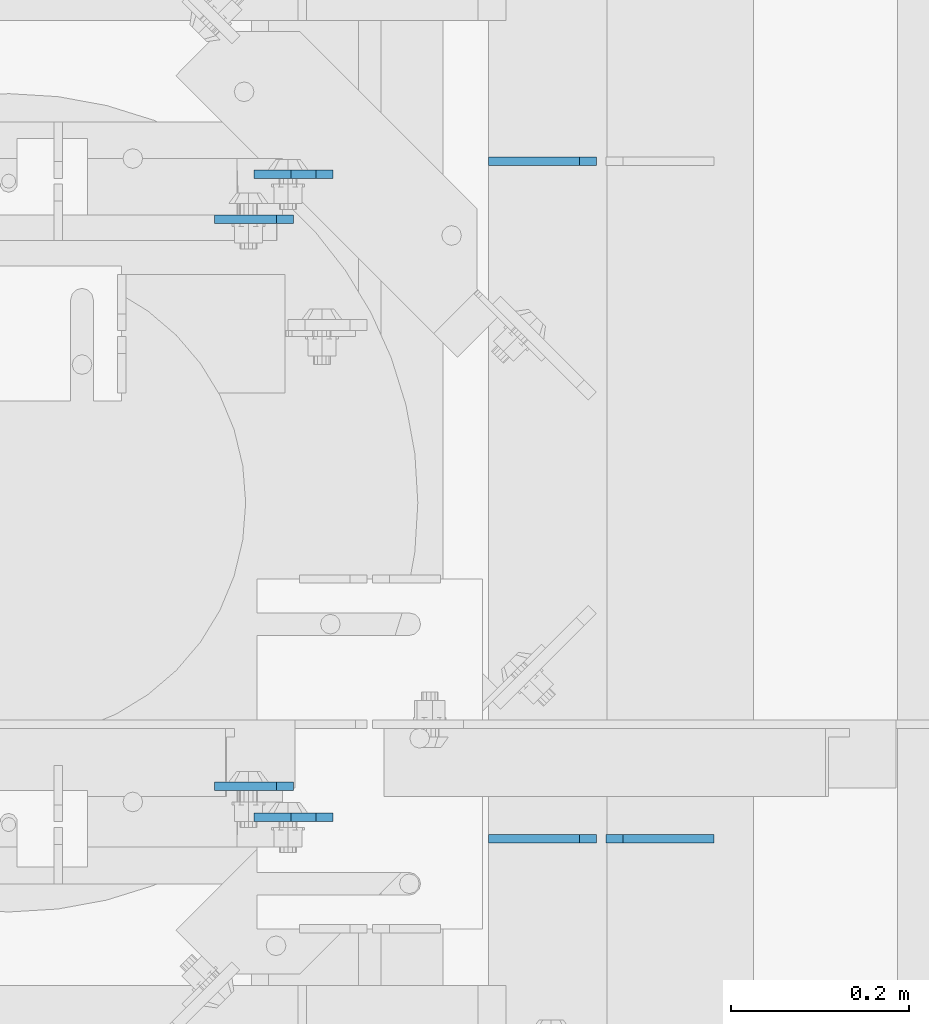
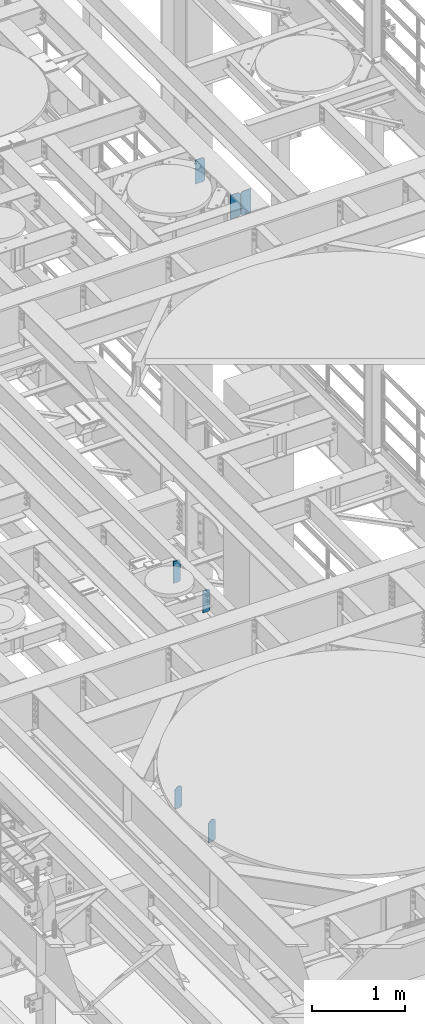
# One storey, part 1640 of 1876: 7 plates, 3 elements without a shape of their own.
"""IFC2X3 building model written with IfcOpenShell, lengths in millimetres."""

from ifc_helpers import new_model, si_unit, frame, origin_with_axes, place, context, subcontext, project, spatial, faceted_brep, material, type_object, element, aggregate, save


model = new_model("IFC2X3")

# Units and contexts
model_context = context("Model", 3, precision=1e-05, world=origin_with_axes())
body_context = subcontext(model_context, "Body", "Model", "MODEL_VIEW")
ifc_project = project(units=[si_unit("LENGTHUNIT", "METRE", prefix="MILLI"), si_unit("AREAUNIT", "SQUARE_METRE"), si_unit("VOLUMEUNIT", "CUBIC_METRE"), si_unit("MASSUNIT", "GRAM", prefix="KILO"), si_unit("TIMEUNIT", "SECOND"), si_unit("PLANEANGLEUNIT", "RADIAN"), si_unit("SOLIDANGLEUNIT", "STERADIAN"), si_unit("THERMODYNAMICTEMPERATUREUNIT", "DEGREE_CELSIUS"), si_unit("LUMINOUSINTENSITYUNIT", "LUMEN")], contexts=[model_context])

# Site, building, storey
site_placement = place(None, origin_with_axes())
site = spatial("IfcSite", under=ifc_project, at=site_placement, CompositionType="ELEMENT")
building_placement = place(site_placement, origin_with_axes())
building = spatial("IfcBuilding", under=site, at=building_placement, Name="Undefined", CompositionType="ELEMENT")
storey_placement = place(building_placement, origin_with_axes())
storey = spatial("IfcBuildingStorey", under=building, at=storey_placement, Name="Undefined", CompositionType="ELEMENT", Elevation=0.0)

# Assembly, plates
assembly_1_placement = place(storey_placement, origin_with_axes())
assembly_1 = element("IfcElementAssembly", 1, at=assembly_1_placement, inside=storey, Name="BEAM", AssemblyPlace="NOTDEFINED", PredefinedType="RIGID_FRAME")
ifc_material = material(Name="STEEL/A36")
plate_type_1 = type_object("IfcPlateType", PredefinedType="NOTDEFINED")
plate_1_placement = place(assembly_1_placement, frame((4740.275, 2122.48532657623, 7856.5375), z_axis=(0.0, 0.0, 1.0), x_axis=(-1.0, 0.0, 0.0)))
plate_1 = element("IfcPlate", 2, at=plate_1_placement, type_object=plate_type_1, material=ifc_material, Name="PLATE", context=body_context, shape_type="Brep", body=[
    faceted_brep([(0.0, -4.76249999999982, 19.0499992370605), (0.0, -4.76249999999982, 271.462512969971), (0.0, 4.76249999999982, 271.462512969971), (0.0, 4.76249999999982, 19.0499992370605), (19.0499992370605, -4.76249999999982, 290.512512207031), (19.0499992370605, 4.76249999999982, 290.512512207031), (88.9000015258789, -4.76249999999982, 290.512512207031), (88.9000015258789, 4.76249999999982, 290.512512207031), (88.9000015258789, -4.76249999999982, 0.0), (88.9000015258789, 4.76249999999982, 0.0), (19.0499992370605, -4.76249999999982, 0.0), (19.0499992370605, 4.76249999999982, 0.0)], [[[0, 1, 2, 3]], [[1, 4, 5, 2]], [[4, 6, 7, 5]], [[6, 8, 9, 7]], [[8, 10, 11, 9]], [[10, 0, 3, 11]], [[5, 7, 9, 11, 3, 2]], [[10, 8, 6, 4, 1, 0]]]),
])
plate_2_placement = place(assembly_1_placement, frame((4740.275, 2760.65916805267, 7856.5375), z_axis=(0.0, 0.0, 1.0), x_axis=(-1.0, 0.0, 0.0)))
plate_2 = element("IfcPlate", 3, at=plate_2_placement, type_object=plate_type_1, material=ifc_material, Name="PLATE", context=body_context, shape_type="Brep", body=[
    faceted_brep([(0.0, -4.76249999999982, 19.0499992370605), (0.0, -4.76249999999982, 271.462512969971), (0.0, 4.76249999999982, 271.462512969971), (0.0, 4.76249999999982, 19.0499992370605), (19.0499992370605, -4.76249999999982, 290.512512207031), (19.0499992370605, 4.76249999999982, 290.512512207031), (88.9000015258789, -4.76249999999982, 290.512512207031), (88.9000015258789, 4.76249999999982, 290.512512207031), (88.9000015258789, -4.76249999999982, 0.0), (88.9000015258789, 4.76249999999982, 0.0), (19.0499992370605, -4.76249999999982, 0.0), (19.0499992370605, 4.76249999999982, 0.0)], [[[0, 1, 2, 3]], [[1, 4, 5, 2]], [[4, 6, 7, 5]], [[6, 8, 9, 7]], [[8, 10, 11, 9]], [[10, 0, 3, 11]], [[5, 7, 9, 11, 3, 2]], [[10, 8, 6, 4, 1, 0]]]),
])
aggregate(assembly_1, [plate_1, plate_2])

assembly_2_placement = place(storey_placement, origin_with_axes())
assembly_2 = element("IfcElementAssembly", 4, at=assembly_2_placement, inside=storey, Name="BEAM", AssemblyPlace="NOTDEFINED", PredefinedType="RIGID_FRAME")
plate_3_placement = place(assembly_2_placement, frame((4784.725, 2811.46299991608, 4833.9375), z_axis=(0.0, 0.0, 1.0), x_axis=(-1.0, 0.0, 0.0)))
plate_3 = element("IfcPlate", 5, at=plate_3_placement, type_object=plate_type_1, material=ifc_material, Name="PLATE", context=body_context, shape_type="Brep", body=[
    faceted_brep([(0.0, -4.76249999999982, 271.462512969971), (19.0499992370605, -4.76249999999982, 290.512512207031), (19.0499992370605, 4.76249999999982, 290.512512207031), (0.0, 4.76249999999982, 271.462512969971), (0.0, -4.76249999999982, 19.0499992370605), (0.0, 4.76249999999982, 19.0499992370605), (19.0499992370605, -4.76249999999982, 0.0), (19.0499992370605, 4.76249999999982, 0.0), (88.9000015258789, -4.76249999999982, 0.0), (88.9000015258789, 4.76249999999982, 0.0), (88.9000015258789, -4.76249999999982, 249.703664491929), (47.6249880912173, -4.76250000000005, 290.512512207031), (47.6249880912173, 4.76250000000005, 290.512512207031), (88.9000015258789, 4.76249999999982, 249.703664491929)], [[[0, 1, 2, 3]], [[4, 0, 3, 5]], [[6, 4, 5, 7]], [[8, 6, 7, 9]], [[1, 0, 4, 6, 8, 10, 11]], [[2, 1, 11, 12]], [[9, 7, 5, 3, 2, 12, 13]], [[8, 9, 13, 10]], [[12, 11, 10, 13]]]),
])
plate_4_placement = place(assembly_2_placement, frame((4784.725, 2087.56299991608, 4833.9375), z_axis=(0.0, 0.0, 1.0), x_axis=(-1.0, 0.0, 0.0)))
plate_4 = element("IfcPlate", 6, at=plate_4_placement, type_object=plate_type_1, material=ifc_material, Name="PLATE", context=body_context, shape_type="Brep", body=[
    faceted_brep([(0.0, -4.76249999999982, 271.462512969971), (19.0499992370605, -4.76249999999982, 290.512512207031), (19.0499992370605, 4.76249999999982, 290.512512207031), (0.0, 4.76249999999982, 271.462512969971), (0.0, -4.76249999999982, 19.0499992370605), (0.0, 4.76249999999982, 19.0499992370605), (19.0499992370605, -4.76249999999982, 0.0), (19.0499992370605, 4.76249999999982, 0.0), (88.9000015258789, -4.76249999999982, 0.0), (88.9000015258789, 4.76249999999982, 0.0), (88.9000015258789, -4.76250000000005, 249.237512489713), (47.6249880912173, -4.76250000000005, 290.512512207031), (47.6249880912173, 4.76250000000005, 290.512512207031), (88.9000015258789, 4.76250000000005, 249.237512489713)], [[[0, 1, 2, 3]], [[4, 0, 3, 5]], [[6, 4, 5, 7]], [[8, 6, 7, 9]], [[1, 0, 4, 6, 8, 10, 11]], [[2, 1, 11, 12]], [[9, 7, 5, 3, 2, 12, 13]], [[8, 9, 13, 10]], [[12, 11, 10, 13]]]),
])
aggregate(assembly_2, [plate_3, plate_4])

assembly_3_placement = place(storey_placement, origin_with_axes())
assembly_3 = element("IfcElementAssembly", 7, at=assembly_3_placement, inside=storey, Name="BEAM", AssemblyPlace="NOTDEFINED", PredefinedType="RIGID_FRAME")
plate_type_2 = type_object("IfcPlateType", PredefinedType="NOTDEFINED")
plate_5_placement = place(assembly_3_placement, frame((5080.79375, 2825.75, 12973.05), z_axis=(0.0, 0.0, 1.0), x_axis=(-1.0, 0.0, 0.0)))
plate_5 = element("IfcPlate", 8, at=plate_5_placement, type_object=plate_type_2, material=ifc_material, Name="PLATE", context=body_context, shape_type="Brep", body=[
    faceted_brep([(0.0, -4.76249999999982, 19.0499992370605), (0.0, -4.76249999999982, 298.450000762939), (0.0, 4.76249999999982, 298.450000762939), (0.0, 4.76249999999982, 19.0499992370605), (19.0499992370605, -4.76249999999982, 317.5), (19.0499992370605, 4.76249999999982, 317.5), (121.443748474121, -4.76249999999982, 317.5), (121.443748474121, 4.76249999999982, 317.5), (121.443748474121, -4.76249999999982, 0.0), (121.443748474121, 4.76249999999982, 0.0), (19.0499992370605, -4.76249999999982, 0.0), (19.0499992370605, 4.76249999999982, 0.0)], [[[0, 1, 2, 3]], [[1, 4, 5, 2]], [[4, 6, 7, 5]], [[6, 8, 9, 7]], [[8, 10, 11, 9]], [[10, 0, 3, 11]], [[5, 7, 9, 11, 3, 2]], [[10, 8, 6, 4, 1, 0]]]),
])
plate_6_placement = place(assembly_3_placement, frame((5213.35, 2063.75, 12973.05), z_axis=(0.0, 0.0, 1.0), x_axis=(-1.0, 0.0, 0.0)))
plate_6 = element("IfcPlate", 9, at=plate_6_placement, type_object=plate_type_2, material=ifc_material, Name="PLATE", context=body_context, shape_type="Brep", body=[
    faceted_brep([(0.0, -4.76249999999982, 0.0), (0.0, -4.76249999999982, 317.5), (0.0, 4.76249999999982, 317.5), (0.0, 4.76249999999982, 0.0), (102.393749237061, -4.76249999999982, 317.5), (102.393749237061, 4.76249999999982, 317.5), (121.443748474121, -4.76249999999982, 298.450000762939), (121.443748474121, 4.76249999999982, 298.450000762939), (121.443748474121, -4.76249999999982, 19.0499992370605), (121.443748474121, 4.76249999999982, 19.0499992370605), (102.393749237061, -4.76249999999982, 0.0), (102.393749237061, 4.76249999999982, 0.0)], [[[0, 1, 2, 3]], [[1, 4, 5, 2]], [[4, 6, 7, 5]], [[6, 8, 9, 7]], [[8, 10, 11, 9]], [[10, 0, 3, 11]], [[5, 7, 9, 11, 3, 2]], [[10, 8, 6, 4, 1, 0]]]),
])
plate_7_placement = place(assembly_3_placement, frame((5080.79375, 2063.75, 12973.05), z_axis=(0.0, 0.0, 1.0), x_axis=(-1.0, 0.0, 0.0)))
plate_7 = element("IfcPlate", 10, at=plate_7_placement, type_object=plate_type_2, material=ifc_material, Name="PLATE", context=body_context, shape_type="Brep", body=[
    faceted_brep([(0.0, -4.76249999999982, 19.0499992370605), (0.0, -4.76249999999982, 298.450000762939), (0.0, 4.76249999999982, 298.450000762939), (0.0, 4.76249999999982, 19.0499992370605), (19.0499992370605, -4.76249999999982, 317.5), (19.0499992370605, 4.76249999999982, 317.5), (121.443748474121, -4.76249999999982, 317.5), (121.443748474121, 4.76249999999982, 317.5), (121.443748474121, -4.76249999999982, 0.0), (121.443748474121, 4.76249999999982, 0.0), (19.0499992370605, -4.76249999999982, 0.0), (19.0499992370605, 4.76249999999982, 0.0)], [[[0, 1, 2, 3]], [[1, 4, 5, 2]], [[4, 6, 7, 5]], [[6, 8, 9, 7]], [[8, 10, 11, 9]], [[10, 0, 3, 11]], [[5, 7, 9, 11, 3, 2]], [[10, 8, 6, 4, 1, 0]]]),
])
aggregate(assembly_3, [plate_5, plate_6, plate_7])

save(model, "model.ifc")
